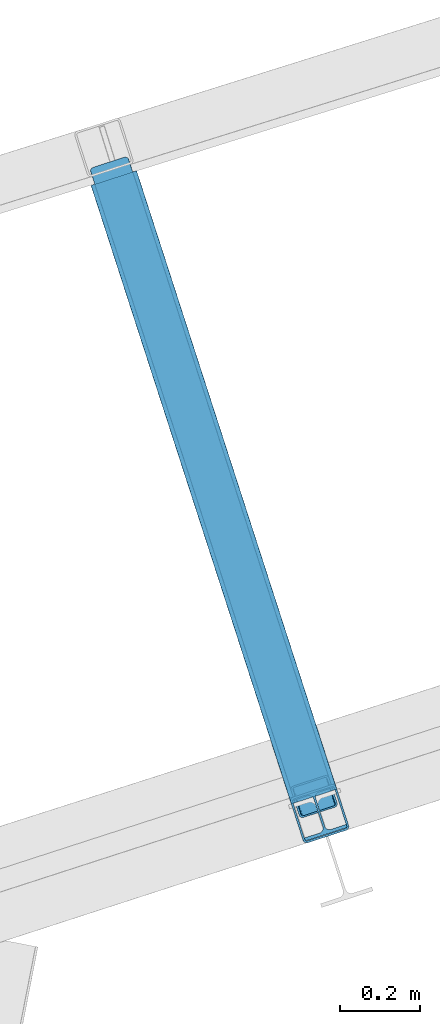
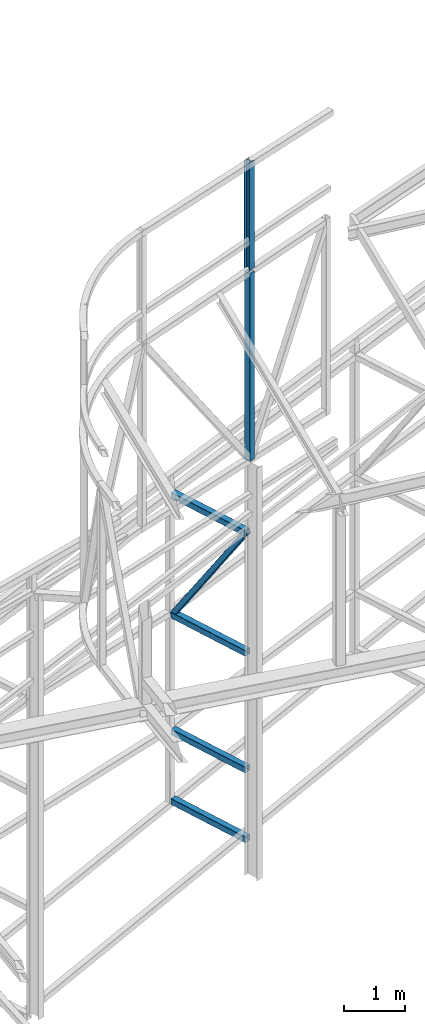
# One storey, part 82 of 215: 6 beams, 1 member, 7 elements without a shape of their own.
"""IFC2X3 building model written with IfcOpenShell, lengths in millimetres."""

from ifc_helpers import new_model, si_unit, frame, origin_with_axes, origin_2d_with_axis, place, context, subcontext, project, spatial, hollow_rectangle, i_section, extrude, material, type_object, element, aggregate, save


model = new_model("IFC2X3")

# Units and contexts
model_context = context("Model", 3, precision=1e-05, world=origin_with_axes())
body_context = subcontext(model_context, "Body", "Model", "MODEL_VIEW")
ifc_project = project(units=[si_unit("LENGTHUNIT", "METRE", prefix="MILLI"), si_unit("AREAUNIT", "SQUARE_METRE"), si_unit("VOLUMEUNIT", "CUBIC_METRE"), si_unit("MASSUNIT", "GRAM", prefix="KILO"), si_unit("TIMEUNIT", "SECOND"), si_unit("PLANEANGLEUNIT", "RADIAN"), si_unit("SOLIDANGLEUNIT", "STERADIAN"), si_unit("THERMODYNAMICTEMPERATUREUNIT", "DEGREE_CELSIUS"), si_unit("LUMINOUSINTENSITYUNIT", "LUMEN")], contexts=[model_context])

# Site, building, storey
site_placement = place(None, origin_with_axes())
site = spatial("IfcSite", under=ifc_project, at=site_placement, CompositionType="ELEMENT")
building_placement = place(site_placement, origin_with_axes())
building = spatial("IfcBuilding", under=site, at=building_placement, Name="Undefined", CompositionType="ELEMENT")
storey_placement = place(building_placement, origin_with_axes())
storey = spatial("IfcBuildingStorey", under=building, at=storey_placement, Name="Undefined", CompositionType="ELEMENT", Elevation=0.0)

# Assembly, beam
assembly_1_placement = place(storey_placement, origin_with_axes())
assembly_1 = element("IfcElementAssembly", 1, at=assembly_1_placement, inside=storey, Name="Steel Assembly", AssemblyPlace="NOTDEFINED", PredefinedType="RIGID_FRAME")
ifc_material = material(Name="STEEL/S275JR")
beam_type_1 = type_object("IfcBeamType", PredefinedType="NOTDEFINED")
beam_1_placement = place(assembly_1_placement, frame((47061.511802026, 60924.5568591593, 4401.39704231813), z_axis=(-0.951354549825319, -0.308098231943425, 0.0), x_axis=(0.30809823194343, -0.951354549825318, -1.99999977269e-09)))
beam_1 = element("IfcBeam", 2, at=beam_1_placement, type_object=beam_type_1, material=ifc_material, context=body_context, shape_type="SweptSolid", body=[
    extrude(hollow_rectangle(XDim=120.0, YDim=120.0, WallThickness=5.0, InnerFilletRadius=5.0, OuterFilletRadius=10.0, at=origin_2d_with_axis()), frame((1627.03077990822, -9.09494701772928e-13, 2.69169699356072e-29), z_axis=(-1.0, 0.0, 0.0), x_axis=(-6.93889390390723e-18, -1.0, -3.46944695195361e-18)), (0.0, 0.0, 1.0), 1627.0),
])
aggregate(assembly_1, [beam_1])

assembly_2_placement = place(storey_placement, origin_with_axes())
assembly_2 = element("IfcElementAssembly", 3, at=assembly_2_placement, inside=storey, Name="Steel Assembly", AssemblyPlace="NOTDEFINED", PredefinedType="RIGID_FRAME")
beam_2_placement = place(assembly_2_placement, frame((47061.5118002023, 60924.5568638089, 689.143217611522), z_axis=(-0.951354549825319, -0.308098231943425, 0.0), x_axis=(0.30809823194343, -0.951354549825318, -1.99999977269e-09)))
beam_2 = element("IfcBeam", 4, at=beam_2_placement, type_object=beam_type_1, material=ifc_material, context=body_context, shape_type="SweptSolid", body=[
    extrude(hollow_rectangle(XDim=120.0, YDim=120.0, WallThickness=5.0, InnerFilletRadius=5.0, OuterFilletRadius=10.0, at=origin_2d_with_axis()), frame((1627.03077990822, -9.09494701772928e-13, 2.69169699356072e-29), z_axis=(-1.0, 0.0, 0.0), x_axis=(-6.93889390390723e-18, -1.0, -3.46944695195361e-18)), (0.0, 0.0, 1.0), 1627.0),
])
aggregate(assembly_2, [beam_2])

assembly_3_placement = place(storey_placement, origin_with_axes())
assembly_3 = element("IfcElementAssembly", 5, at=assembly_3_placement, inside=storey, Name="Steel Assembly", AssemblyPlace="NOTDEFINED", PredefinedType="RIGID_FRAME")
beam_3_placement = place(assembly_3_placement, frame((47061.5118019427, 60924.5568594074, 2077.33977195709), z_axis=(-0.951354549825319, -0.308098231943425, 0.0), x_axis=(0.30809823194343, -0.951354549825318, -1.99999977269e-09)))
beam_3 = element("IfcBeam", 6, at=beam_3_placement, type_object=beam_type_1, material=ifc_material, context=body_context, shape_type="SweptSolid", body=[
    extrude(hollow_rectangle(XDim=120.0, YDim=120.0, WallThickness=5.0, InnerFilletRadius=5.0, OuterFilletRadius=10.0, at=origin_2d_with_axis()), frame((1627.03077990822, -9.09494701772928e-13, 2.69169699356072e-29), z_axis=(-1.0, 0.0, 0.0), x_axis=(-6.93889390390723e-18, -1.0, -3.46944695195361e-18)), (0.0, 0.0, 1.0), 1627.0),
])
aggregate(assembly_3, [beam_3])

assembly_4_placement = place(storey_placement, origin_with_axes())
assembly_4 = element("IfcElementAssembly", 7, at=assembly_4_placement, inside=storey, Name="Steel Assembly", AssemblyPlace="NOTDEFINED", PredefinedType="RIGID_FRAME")
beam_4_placement = place(assembly_4_placement, frame((47061.5117984122, 60924.5568555716, 6789.61054494785), z_axis=(-0.951355977985299, -0.308093821995242, 0.0), x_axis=(0.30809382199524, -0.951355977985299, -1.9999999219307e-09)))
beam_4 = element("IfcBeam", 8, at=beam_4_placement, type_object=beam_type_1, material=ifc_material, context=body_context, shape_type="SweptSolid", body=[
    extrude(hollow_rectangle(XDim=120.0, YDim=120.0, WallThickness=5.0, InnerFilletRadius=5.0, OuterFilletRadius=10.0, at=origin_2d_with_axis()), frame((1627.0191685949, -9.09494701772928e-13, 7.27595761418343e-12), z_axis=(-1.0, 0.0, 0.0), x_axis=(-6.93889390390723e-18, -1.0, -3.46944695195361e-18)), (0.0, 0.0, 1.0), 1627.0),
])
aggregate(assembly_4, [beam_4])

assembly_5_placement = place(storey_placement, origin_with_axes())
assembly_5 = element("IfcElementAssembly", 9, at=assembly_5_placement, inside=storey, Name="Steel Assembly", AssemblyPlace="NOTDEFINED", PredefinedType="RIGID_FRAME")
beam_5_placement = place(assembly_5_placement, frame((47576.6696782598, 59333.8636828899, 12014.6614985694), z_axis=(0.308275434998926, -0.951297143996671, -1.00000033853226e-09), x_axis=(0.0, 0.0, -1.0)))
beam_5 = element("IfcBeam", 10, at=beam_5_placement, type_object=beam_type_1, material=ifc_material, Name="LISSE", context=body_context, shape_type="SweptSolid", body=[
    extrude(hollow_rectangle(XDim=120.0, YDim=120.0, WallThickness=5.0, InnerFilletRadius=5.0, OuterFilletRadius=10.0, at=origin_2d_with_axis()), frame((3743.53386809591, 0.0, 0.0), z_axis=(-1.0, 0.0, 0.0), x_axis=(-6.93889390390723e-18, -1.0, -3.46944695195361e-18)), (0.0, 0.0, 1.0), 3743.5),
])
aggregate(assembly_5, [beam_5])

# Assembly, member
assembly_6_placement = place(storey_placement, origin_with_axes())
assembly_6 = element("IfcElementAssembly", 11, at=assembly_6_placement, inside=storey, Name="Steel Assembly", AssemblyPlace="NOTDEFINED", PredefinedType="RIGID_FRAME")
member_type = type_object("IfcMemberType", PredefinedType="NOTDEFINED")
member_placement = place(assembly_6_placement, frame((47562.8158484445, 59376.6912181851, 6809.61054169876), z_axis=(-0.951267507585373, -0.308366820865597, -0.000181111999921272), x_axis=(-0.172487661075394, 0.532586414232793, -0.828613129362187)))
member = element("IfcMember", 12, at=member_placement, type_object=member_type, material=ifc_material, context=body_context, shape_type="SweptSolid", body=[
    extrude(hollow_rectangle(XDim=100.0, YDim=100.0, WallThickness=5.0, InnerFilletRadius=5.0, OuterFilletRadius=10.0, at=origin_2d_with_axis()), frame((2906.31829728468, 6.95329146512994e-12, 7.13857241790675e-12), z_axis=(-1.0, 0.0, 0.0), x_axis=(-6.93889390390723e-18, -1.0, -3.46944695195361e-18)), (0.0, 0.0, 1.0), 2906.3),
])
aggregate(assembly_6, [member])

# Assembly, beam
assembly_7_placement = place(storey_placement, origin_with_axes())
assembly_7 = element("IfcElementAssembly", 13, at=assembly_7_placement, inside=storey, Name="Steel Assembly", AssemblyPlace="NOTDEFINED", PredefinedType="RIGID_FRAME")
beam_type_2 = type_object("IfcBeamType", Name="HEA120", PredefinedType="NOTDEFINED")
beam_6_placement = place(assembly_7_placement, frame((47575.7448369618, 59336.7175693039, 14219.9969924568), z_axis=(0.308275434998926, -0.951297143996671, -1.00000033853226e-09), x_axis=(0.0, 0.0, -1.0)))
beam_6 = element("IfcBeam", 14, at=beam_6_placement, type_object=beam_type_2, material=ifc_material, ObjectType="HEA120", context=body_context, shape_type="SweptSolid", body=[
    extrude(i_section(OverallWidth=120.0, OverallDepth=114.0, WebThickness=5.0, FlangeThickness=8.0, FilletRadius=12.0, at=origin_2d_with_axis()), frame((2143.45035433288, 0.0, 7.27595761418343e-12), z_axis=(-1.0, 0.0, 0.0), x_axis=(-6.93889390390723e-18, -1.0, -3.46944695195361e-18)), (0.0, 0.0, 1.0), 2143.5),
])
aggregate(assembly_7, [beam_6])

save(model, "model.ifc")
